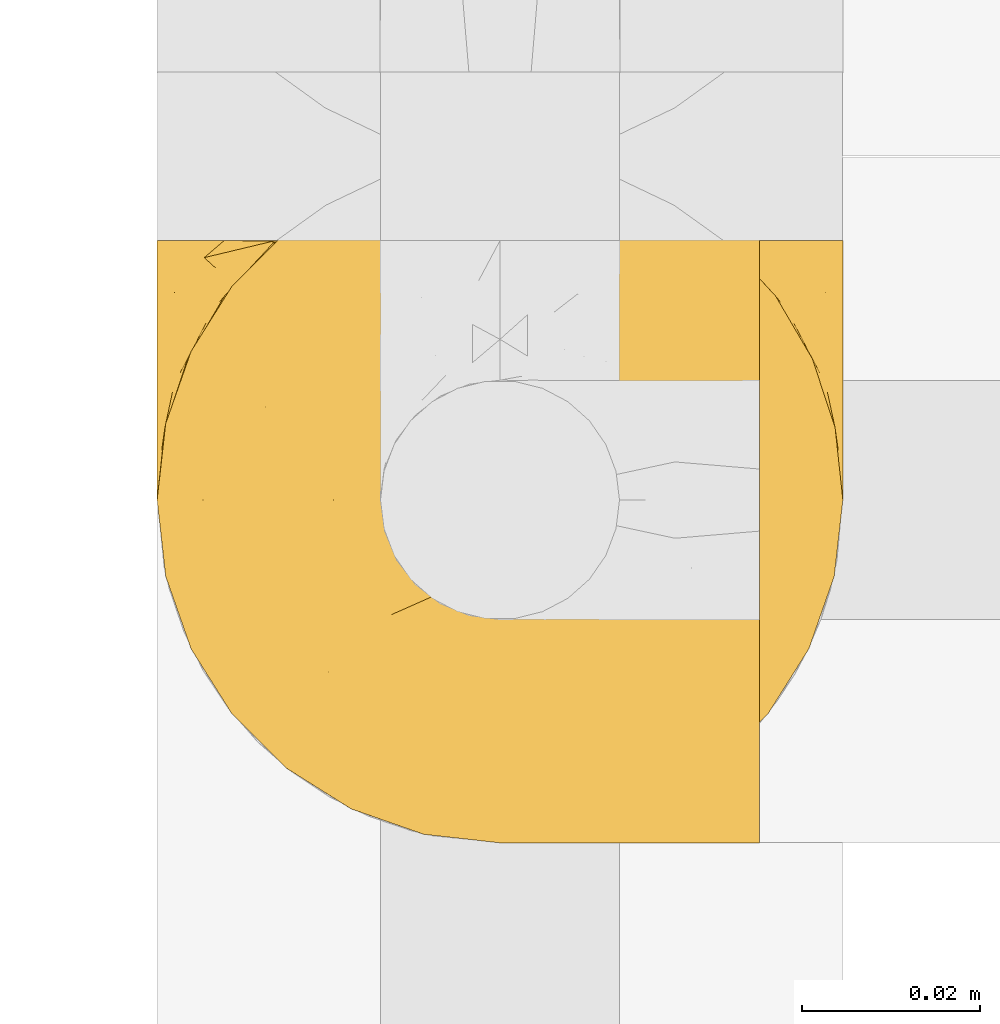
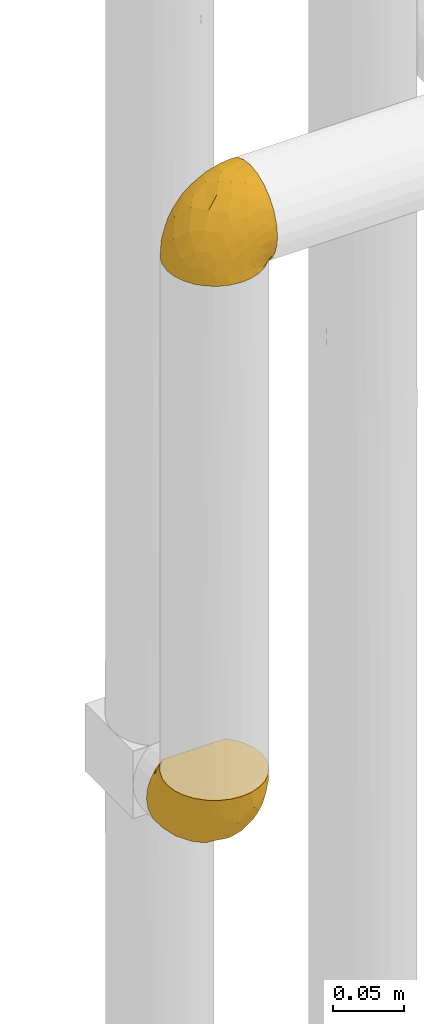
# One storey, part 289 of 827: 2 coverings.
"""IFC2X3 building model written with IfcOpenShell, lengths in millimetres."""

import ifcopenshell
import ifcopenshell.guid

model = None  # the IFC model being written
_history = None  # IfcOwnerHistory: only IFC2X3 demands one
_inside = {}  # id of a spatial element -> (the spatial element, [elements in it])
_under = {}  # id of a project, library or spatial element -> (it, [spatial elements below it])
_declared = {}  # id of a project -> (the project, [libraries it declares])
_typed = {}  # id of a type object -> (the type object, [elements of that type])
_made_of = {}  # id of a material, layer set ... -> (it, [elements and type objects made of it])


def new_model(schema):
    """Start an empty IFC model of exactly this schema.

    Asked for "IFC4X3", IfcOpenShell would pick the latest addendum, in which some entities
    have other attributes; the version numbers below select the first issue.
    IFC2X3 requires an IfcOwnerHistory on every rooted entity: one is made here for all.
    """
    global model, _history
    if schema == "IFC4X3":
        model = ifcopenshell.file(schema_version=(4, 3, 0, 0))
    else:
        model = ifcopenshell.file(schema=schema)
    _inside.clear()
    _under.clear()
    _declared.clear()
    _typed.clear()
    _made_of.clear()
    _history = None
    if model.schema == "IFC2X3":
        org = make("IfcOrganization", Name="unknown")
        user = make(
            "IfcPersonAndOrganization",
            ThePerson=make("IfcPerson", FamilyName="unknown"),
            TheOrganization=org,
        )
        app = make(
            "IfcApplication",
            ApplicationDeveloper=org,
            Version="unknown",
            ApplicationFullName="unknown",
            ApplicationIdentifier="unknown",
        )
        _history = make(
            "IfcOwnerHistory",
            OwningUser=user,
            OwningApplication=app,
            ChangeAction="ADDED",
            CreationDate=0,
        )
    return model


def make(cls, **values):
    """One entity of the class cls with the attributes given. An attribute that is None is left unset."""
    return model.create_entity(
        cls, **{name: value for name, value in values.items() if value is not None}
    )


def entity(cls, *values):
    """Any entity or typed value of the class cls, its attributes in the order of the schema. None: left unset."""
    e = model.create_entity(cls)
    for i, value in enumerate(values):
        if value is not None:
            e[i] = value
    return e


def rooted(cls, **values):
    """An entity with a GlobalId (a new one), such as an element, a storey or a relation."""
    return make(cls, GlobalId=ifcopenshell.guid.new(), OwnerHistory=_history, **values)


def si_unit(unit_type, name, prefix=None):
    """IfcSIUnit, for example si_unit("LENGTHUNIT", "METRE", prefix="MILLI")."""
    return make("IfcSIUnit", UnitType=unit_type, Prefix=prefix, Name=name)


def converted_unit(unit_type, name, factor, base, dimensions=None, offset=None):
    """IfcConversionBasedUnit, such as the inch: factor (a typed value) times the base unit."""
    return make(
        "IfcConversionBasedUnit"
        if offset is None
        else "IfcConversionBasedUnitWithOffset",
        ConversionOffset=offset,
        Dimensions=None
        if dimensions is None
        else entity("IfcDimensionalExponents", *dimensions),
        UnitType=unit_type,
        Name=name,
        ConversionFactor=make(
            "IfcMeasureWithUnit", ValueComponent=factor, UnitComponent=base
        ),
    )


def derived_unit(unit_type, elements):
    """IfcDerivedUnit: a product of units, each with its exponent."""
    return make(
        "IfcDerivedUnit",
        Elements=[
            make("IfcDerivedUnitElement", Unit=unit, Exponent=power)
            for unit, power in elements
        ],
        UnitType=unit_type,
    )


def assignment(units):
    """IfcUnitAssignment: the units of a project."""
    return None if units is None else make("IfcUnitAssignment", Units=units)


def point(xyz):
    """IfcCartesianPoint."""
    return None if xyz is None else make("IfcCartesianPoint", Coordinates=xyz)


def direction(xyz):
    """IfcDirection."""
    return None if xyz is None else make("IfcDirection", DirectionRatios=xyz)


def frame(location, z_axis=None, x_axis=None):
    """IfcAxis2Placement3D, a coordinate frame: its origin and axes. An axis left out is left unset."""
    return make(
        "IfcAxis2Placement3D",
        Location=point(location),
        Axis=direction(z_axis),
        RefDirection=direction(x_axis),
    )


def origin():
    """The frame at (0, 0, 0) with its axes left unset."""
    return frame((0.0, 0.0, 0.0))


def place(relative_to, where):
    """IfcLocalPlacement: puts the frame where relative to a parent placement (None: the world)."""
    return make(
        "IfcLocalPlacement", PlacementRelTo=relative_to, RelativePlacement=where
    )


def context(
    kind, dimensions, precision=None, world=None, true_north=None, identifier=None
):
    """IfcGeometricRepresentationContext, for example the 3D "Model" context."""
    return make(
        "IfcGeometricRepresentationContext",
        ContextIdentifier=identifier,
        ContextType=kind,
        CoordinateSpaceDimension=dimensions,
        Precision=precision,
        WorldCoordinateSystem=world,
        TrueNorth=true_north,
    )


def subcontext(parent, identifier, kind, view, scale=None):
    """IfcGeometricRepresentationSubContext, for example "Body" below "Model"."""
    return make(
        "IfcGeometricRepresentationSubContext",
        ContextIdentifier=identifier,
        ContextType=kind,
        ParentContext=parent,
        TargetScale=scale,
        TargetView=view,
    )


def project(units=None, contexts=None):
    """IfcProject with its units and contexts."""
    return rooted(
        "IfcProject",
        Name="project",
        RepresentationContexts=contexts,
        UnitsInContext=assignment(units),
    )


def spatial(cls, under=None, at=None, **own):
    """A site, building, storey or space (cls), placed at a placement, below another one or the project."""
    s = rooted(cls, ObjectPlacement=at, **own)
    if under is not None:
        _under.setdefault(under.id(), (under, []))[1].append(s)
    return s


def faces_of(points, faces, orient=None, outer=None):
    """IfcFace entities. A face is a list of loops; a loop is a list of indices into points, from 0.

    orient and outer hold one flag for each loop. By default every Orientation is true, the
    first loop of a face is its IfcFaceOuterBound and the others are IfcFaceBound.
    """
    made = []
    for i, loops in enumerate(faces):
        bounds = []
        for j, loop in enumerate(loops):
            is_outer = j == 0 if outer is None else outer[i][j]
            bounds.append(
                make(
                    "IfcFaceOuterBound" if is_outer else "IfcFaceBound",
                    Bound=make("IfcPolyLoop", Polygon=[points[k] for k in loop]),
                    Orientation=True if orient is None else orient[i][j],
                )
            )
        made.append(make("IfcFace", Bounds=bounds))
    return made


def faceted_brep(points, faces, orient=None, outer=None, voids=None):
    """IfcFacetedBrep: a solid bounded by flat faces; with voids (closed shells), ...WithVoids."""
    shared = [point(p) for p in points]
    hull = make("IfcClosedShell", CfsFaces=faces_of(shared, faces, orient, outer))
    if voids is None:
        return make("IfcFacetedBrep", Outer=hull)
    return make(
        "IfcFacetedBrepWithVoids",
        Outer=hull,
        Voids=[
            make(cls, CfsFaces=faces_of(shared, fs, o, b)) for cls, fs, o, b in voids
        ],
    )


def shape(context_of_items, identifier, shape_type, items):
    """IfcShapeRepresentation: the items that make up one representation, for example the "Body"."""
    return make(
        "IfcShapeRepresentation",
        ContextOfItems=context_of_items,
        RepresentationIdentifier=identifier,
        RepresentationType=shape_type,
        Items=items,
    )


def made_of(thing, what):
    """Note that an element or type object is made of a material, layer set ...; save() writes the relation."""
    if what is not None:
        _made_of.setdefault(what.id(), (what, []))[1].append(thing)
    return thing


def element(
    cls,
    number,
    at=None,
    inside=None,
    cuts=None,
    type_object=None,
    material=None,
    context=None,
    identifier="Body",
    shape_type=None,
    held_by="IfcProductDefinitionShape",
    body=None,
    shapes=None,
    **own,
):
    """One element of the class cls, such as IfcWall. Its Tag is "e" and its number.

    at: its placement. inside: the storey or other place that contains it. cuts: it is an
    opening in that element (IfcRelVoidsElement). A single representation is given by context,
    identifier, shape_type and body (its items); several are given by shapes. held_by: the class
    of the entity that holds the representations. save() writes the other relations.
    """
    e = rooted(cls, Tag="e%d" % number, ObjectPlacement=at, **own)
    if body is not None:
        shapes = [shape(context, identifier, shape_type, body)]
    if shapes is not None:
        e.Representation = make(held_by, Representations=shapes)
    if inside is not None:
        _inside.setdefault(inside.id(), (inside, []))[1].append(e)
    if cuts is not None:
        rooted(
            "IfcRelVoidsElement", RelatingBuildingElement=cuts, RelatedOpeningElement=e
        )
    if type_object is not None:
        _typed.setdefault(type_object.id(), (type_object, []))[1].append(e)
    return made_of(e, material)


def aggregate(whole, parts):
    """IfcRelAggregates: a whole, such as a stair, and the parts it consists of."""
    return rooted("IfcRelAggregates", RelatingObject=whole, RelatedObjects=parts)


def save(model, path):
    """Write the relations noted so far, then the file.

    IfcRelAggregates (storeys below a building ...), IfcRelContainedInSpatialStructure (elements
    in a storey), IfcRelDefinesByType, IfcRelAssociatesMaterial and IfcRelDeclares: one each for
    every whole, place, type object, material and project.
    """
    for whole, parts in _under.values():
        aggregate(whole, parts)
    for where, things in _inside.values():
        rooted(
            "IfcRelContainedInSpatialStructure",
            RelatedElements=things,
            RelatingStructure=where,
        )
    for kind, things in _typed.values():
        rooted("IfcRelDefinesByType", RelatedObjects=things, RelatingType=kind)
    for what, things in _made_of.values():
        rooted("IfcRelAssociatesMaterial", RelatedObjects=things, RelatingMaterial=what)
    for by, libraries in _declared.values():
        rooted("IfcRelDeclares", RelatingContext=by, RelatedDefinitions=libraries)
    model.write(path)


model = new_model("IFC2X3")

# Units and contexts
model_context = context("Model", 3, precision=0.01, world=origin(), true_north=direction((6.12303176911189e-17, 1.0)))
body_context = subcontext(model_context, "Body", "Model", "MODEL_VIEW")
ifc_project = project(units=[si_unit("LENGTHUNIT", "METRE", prefix="MILLI"), si_unit("AREAUNIT", "SQUARE_METRE"), si_unit("VOLUMEUNIT", "CUBIC_METRE"), converted_unit("PLANEANGLEUNIT", "DEGREE", entity("IfcRatioMeasure", 0.0174532925199433), si_unit("PLANEANGLEUNIT", "RADIAN"), dimensions=[0, 0, 0, 0, 0, 0, 0]), si_unit("MASSUNIT", "GRAM", prefix="KILO"), derived_unit("MASSDENSITYUNIT", [(si_unit("MASSUNIT", "GRAM", prefix="KILO"), 1), (si_unit("LENGTHUNIT", "METRE"), -3)]), derived_unit("MOMENTOFINERTIAUNIT", [(si_unit("LENGTHUNIT", "METRE"), 4)]), si_unit("TIMEUNIT", "SECOND"), si_unit("FREQUENCYUNIT", "HERTZ"), si_unit("THERMODYNAMICTEMPERATUREUNIT", "DEGREE_CELSIUS"), derived_unit("THERMALTRANSMITTANCEUNIT", [(si_unit("MASSUNIT", "GRAM", prefix="KILO"), 1), (si_unit("THERMODYNAMICTEMPERATUREUNIT", "KELVIN"), -1), (si_unit("TIMEUNIT", "SECOND"), -3)]), derived_unit("VOLUMETRICFLOWRATEUNIT", [(si_unit("LENGTHUNIT", "METRE"), 3), (si_unit("TIMEUNIT", "SECOND"), -1)]), derived_unit("MASSFLOWRATEUNIT", [(si_unit("MASSUNIT", "GRAM", prefix="KILO"), 1), (si_unit("TIMEUNIT", "SECOND"), -1)]), derived_unit("ROTATIONALFREQUENCYUNIT", [(si_unit("TIMEUNIT", "SECOND"), -1)]), si_unit("ELECTRICCURRENTUNIT", "AMPERE"), si_unit("ELECTRICVOLTAGEUNIT", "VOLT"), si_unit("POWERUNIT", "WATT"), si_unit("FORCEUNIT", "NEWTON", prefix="KILO"), si_unit("ILLUMINANCEUNIT", "LUX"), si_unit("LUMINOUSFLUXUNIT", "LUMEN"), si_unit("LUMINOUSINTENSITYUNIT", "CANDELA"), derived_unit("USERDEFINED", [(si_unit("MASSUNIT", "GRAM", prefix="KILO"), -1), (si_unit("LENGTHUNIT", "METRE"), -2), (si_unit("TIMEUNIT", "SECOND"), 3), (si_unit("LUMINOUSFLUXUNIT", "LUMEN"), 1)]), derived_unit("LINEARVELOCITYUNIT", [(si_unit("LENGTHUNIT", "METRE"), 1), (si_unit("TIMEUNIT", "SECOND"), -1)]), si_unit("PRESSUREUNIT", "PASCAL"), derived_unit("USERDEFINED", [(si_unit("LENGTHUNIT", "METRE"), -2), (si_unit("MASSUNIT", "GRAM", prefix="KILO"), 1), (si_unit("TIMEUNIT", "SECOND"), -2)]), derived_unit("LINEARFORCEUNIT", [(si_unit("MASSUNIT", "GRAM", prefix="KILO"), 1), (si_unit("LENGTHUNIT", "METRE"), 1), (si_unit("TIMEUNIT", "SECOND"), -2), (si_unit("LENGTHUNIT", "METRE"), -1)]), derived_unit("PLANARFORCEUNIT", [(si_unit("MASSUNIT", "GRAM", prefix="KILO"), 1), (si_unit("LENGTHUNIT", "METRE"), 1), (si_unit("TIMEUNIT", "SECOND"), -2), (si_unit("LENGTHUNIT", "METRE"), -2)])], contexts=[model_context])

# Site, building, storey
site_placement = place(None, origin())
site = spatial("IfcSite", under=ifc_project, at=site_placement, CompositionType="ELEMENT")
building_placement = place(site_placement, origin())
building = spatial("IfcBuilding", under=site, at=building_placement, CompositionType="ELEMENT")
storey_placement = place(building_placement, frame((0.0, 0.0, 28200.0)))
storey = spatial("IfcBuildingStorey", under=building, at=storey_placement, Name="08", CompositionType="ELEMENT", Elevation=28200.0)

# Coverings
covering_1_placement = place(storey_placement, frame((34787.8, 15705.01, 2179.3)))
element("IfcCovering", 1, at=covering_1_placement, inside=storey, Name=":ADSK_", ObjectType=":ADSK_", PredefinedType="INSULATION", context=body_context, shape_type="Brep", body=[
    faceted_brep([(23.36, 5.41, 1.6), (16.07, 9.99, 1.6), (9.98, 16.08, 1.6), (5.4, 23.37, 1.6), (2.56, 31.49, 1.6), (1.6, 40.05, 1.6), (2.56, 48.61, 1.6), (5.41, 56.73, 1.6), (9.99, 64.02, 1.6), (16.08, 70.11, 1.6), (23.37, 74.69, 1.6), (31.49, 77.53, 1.6), (40.05, 78.5, 1.6), (48.15, 77.63, 1.6), (55.88, 75.08, 1.6), (62.9, 70.97, 1.6), (68.89, 65.47, 1.6), (68.89, 63.27, 1.6), (68.89, 61.53, 1.6), (68.89, 59.57, 1.6), (68.89, 57.6, 1.6), (68.89, 55.63, 1.6), (68.89, 53.67, 1.6), (68.89, 51.7, 1.6), (68.89, 49.73, 1.6), (68.89, 47.54, 1.6), (68.89, 45.34, 1.6), (68.89, 43.15, 1.6), (68.89, 40.96, 1.6), (68.89, 38.76, 1.6), (68.89, 36.57, 1.6), (68.89, 34.37, 1.6), (68.89, 32.18, 1.6), (68.89, 29.98, 1.6), (68.89, 27.79, 1.6), (68.89, 25.6, 1.6), (68.89, 23.4, 1.6), (68.89, 21.21, 1.6), (68.89, 19.01, 1.6), (68.89, 16.82, 1.6), (68.89, 14.62, 1.6), (62.89, 9.12, 1.6), (55.86, 5.0, 1.6), (48.13, 2.46, 1.6), (40.05, 1.6, 1.6), (31.49, 2.56, 1.6), (69.15, 65.47, 1.85), (69.15, 70.97, 7.85), (69.15, 75.09, 14.87), (69.15, 77.63, 22.6), (69.15, 78.5, 30.7), (69.15, 77.19, 40.65), (69.15, 73.34, 49.92), (69.15, 67.23, 57.88), (69.15, 59.27, 63.99), (69.15, 50.0, 67.84), (69.15, 40.05, 69.15), (69.15, 30.09, 67.84), (69.15, 20.82, 63.99), (69.15, 12.86, 57.88), (69.15, 6.75, 49.92), (69.15, 2.91, 40.65), (69.15, 1.6, 30.7), (69.15, 2.46, 22.6), (69.15, 5.0, 14.87), (69.15, 9.12, 7.85), (69.15, 14.62, 1.85), (69.15, 16.82, 1.85), (69.15, 17.8, 1.85), (69.15, 19.39, 1.85), (69.15, 20.98, 1.85), (69.15, 22.57, 1.85), (69.15, 24.16, 1.85), (69.15, 25.75, 1.85), (69.15, 27.33, 1.85), (69.15, 28.92, 1.85), (69.15, 30.51, 1.85), (69.15, 32.1, 1.85), (69.15, 33.69, 1.85), (69.15, 35.28, 1.85), (69.15, 36.87, 1.85), (69.15, 38.46, 1.85), (69.15, 40.05, 1.85), (69.15, 41.63, 1.85), (69.15, 43.22, 1.85), (69.15, 44.81, 1.85), (69.15, 46.4, 1.85), (69.15, 47.99, 1.85), (69.15, 49.58, 1.85), (69.15, 51.17, 1.85), (69.15, 52.76, 1.85), (69.15, 54.72, 1.85), (69.15, 56.69, 1.85), (69.15, 58.88, 1.85), (69.15, 61.08, 1.85), (69.15, 63.27, 1.85), (68.96, 37.77, 1.77), (68.97, 36.07, 1.78), (68.97, 32.96, 1.77), (68.97, 31.36, 1.77), (68.95, 56.52, 1.76), (68.96, 54.96, 1.77), (68.98, 18.75, 1.79), (68.97, 58.07, 1.78), (68.97, 50.37, 1.78), (68.98, 23.36, 1.78), (68.97, 24.95, 1.78), (68.97, 42.43, 1.78), (68.94, 15.97, 1.74), (68.98, 51.96, 1.78), (68.98, 53.47, 1.78), (68.96, 48.63, 1.77), (68.97, 63.93, 1.78), (68.98, 40.93, 1.78), (68.98, 29.72, 1.78), (68.97, 62.4, 1.77), (68.96, 60.92, 1.77), (68.97, 17.31, 1.77), (68.97, 21.74, 1.78), (68.98, 34.56, 1.78), (68.96, 20.18, 1.77), (68.97, 14.62, 1.77), (68.94, 14.62, 1.72), (68.92, 14.62, 1.66), (68.97, 65.47, 1.77), (69.02, 65.47, 1.8), (69.08, 65.47, 1.82), (68.98, 59.5, 1.79), (68.97, 47.1, 1.78), (68.98, 45.61, 1.79), (68.97, 28.18, 1.78), (69.08, 14.62, 1.82), (69.02, 14.62, 1.8), (68.96, 26.61, 1.76), (68.92, 65.47, 1.66), (68.94, 65.47, 1.72), (68.97, 39.32, 1.78), (68.96, 44.12, 1.77), (67.02, 72.26, 9.41), (63.33, 76.57, 17.65), (64.61, 71.77, 7.41), (49.27, 78.5, 21.47), (51.4, 77.9, 15.21), (43.94, 78.5, 16.15), (61.87, 78.5, 28.75), (61.54, 75.52, 13.67), (57.95, 76.13, 12.79), (56.12, 77.81, 19.18), (63.4, 78.5, 29.16), (65.41, 72.4, 9.04), (53.1, 76.56, 7.41), (63.04, 71.77, 5.74), (61.33, 72.25, 3.72), (41.99, 78.5, 8.87), (54.6, 78.5, 26.8), (56.6, 75.75, 9.53), (41.58, 78.5, 7.34), (13.72, 50.46, 37.63), (5.82, 52.75, 17.92), (6.74, 40.05, 27.45), (58.82, 77.7, 37.01), (51.58, 77.66, 34.22), (42.09, 71.02, 45.87), (46.12, 63.45, 56.57), (55.56, 70.55, 52.31), (52.38, 75.57, 42.07), (61.54, 75.57, 44.74), (23.76, 72.61, 21.49), (20.5, 72.61, 11.02), (14.64, 67.24, 15.64), (41.77, 77.74, 26.02), (16.28, 57.43, 36.59), (49.4, 47.19, 65.49), (52.34, 54.76, 63.99), (4.3, 40.05, 15.2), (58.67, 63.45, 60.27), (25.26, 60.1, 45.25), (20.17, 63.72, 35.21), (34.7, 76.83, 22.52), (28.67, 76.34, 12.03), (8.62, 60.51, 13.32), (33.37, 72.59, 35.9), (41.35, 76.05, 33.87), (17.15, 66.15, 25.73), (12.68, 60.51, 26.34), (21.47, 51.88, 46.78), (41.11, 55.34, 59.54), (37.53, 48.67, 60.18), (30.64, 53.89, 53.93), (26.66, 46.73, 53.36), (21.38, 40.05, 49.36), (14.06, 40.05, 38.4), (55.54, 40.05, 66.44), (35.17, 63.95, 50.09), (29.04, 67.24, 41.08), (24.34, 69.62, 31.14), (29.33, 73.6, 28.19), (43.3, 40.05, 64.0), (32.34, 40.05, 56.68), (57.75, 4.52, 43.9), (49.41, 32.72, 65.46), (27.85, 27.18, 52.22), (13.7, 29.63, 37.61), (14.63, 12.86, 15.64), (8.61, 19.59, 13.31), (48.85, 9.54, 50.02), (54.13, 16.64, 59.28), (37.84, 17.48, 53.05), (23.75, 7.49, 21.48), (20.49, 7.49, 11.01), (28.66, 3.75, 12.03), (20.83, 20.75, 41.02), (55.15, 2.33, 35.39), (54.6, 1.6, 26.8), (61.87, 1.6, 28.75), (41.58, 1.6, 7.34), (57.58, 26.94, 65.81), (59.91, 9.54, 53.28), (36.94, 31.21, 59.8), (45.72, 25.33, 61.82), (5.82, 27.35, 17.91), (37.91, 8.17, 41.4), (50.18, 4.3, 40.48), (12.67, 19.59, 26.34), (49.29, 2.23, 31.68), (42.64, 2.45, 27.68), (43.94, 1.6, 16.15), (49.27, 1.6, 21.47), (19.45, 12.86, 28.05), (34.7, 3.27, 22.54), (41.99, 1.6, 8.87), (62.29, 2.29, 37.3), (29.01, 12.86, 41.07), (31.47, 6.89, 32.24), (37.18, 12.43, 47.4), (43.45, 4.1, 35.77), (63.33, 3.53, 17.65), (67.23, 6.88, 11.06), (66.07, 8.16, 8.55), (65.22, 9.02, 6.63), (61.99, 5.0, 12.77), (57.95, 3.96, 12.79), (53.09, 3.52, 7.41), (56.84, 2.4, 18.97), (61.33, 7.83, 3.72), (63.06, 8.32, 5.76), (51.41, 2.19, 15.21), (56.61, 4.34, 9.52)], [[[0, 1, 2, 3, 4, 5, 6, 7, 8, 9, 10, 11, 12, 13, 14, 15, 16, 17, 18, 19, 20, 21, 22, 23, 24, 25, 26, 27, 28, 29, 30, 31, 32, 33, 34, 35, 36, 37, 38, 39, 40, 41, 42, 43, 44, 45]], [[46, 47, 48, 49, 50, 51, 52, 53, 54, 55, 56, 57, 58, 59, 60, 61, 62, 63, 64, 65, 66, 67, 68, 69, 70, 71, 72, 73, 74, 75, 76, 77, 78, 79, 80, 81, 82, 83, 84, 85, 86, 87, 88, 89, 90, 91, 92, 93, 94, 95]], [[96, 97, 30]], [[98, 77, 99]], [[100, 101, 21]], [[69, 68, 102]], [[20, 19, 103]], [[24, 23, 104]], [[20, 103, 100]], [[72, 105, 106]], [[84, 83, 107]], [[89, 88, 104]], [[108, 67, 66]], [[109, 110, 90]], [[111, 25, 24]], [[112, 17, 16]], [[82, 113, 83]], [[109, 23, 22]], [[114, 76, 75]], [[105, 36, 106]], [[104, 111, 24]], [[18, 115, 116]], [[97, 96, 80]], [[67, 108, 117]], [[105, 71, 118]], [[31, 97, 119]], [[102, 120, 69]], [[108, 121, 122, 123, 40]], [[112, 95, 115]], [[17, 115, 18]], [[94, 116, 115]], [[117, 68, 67]], [[38, 117, 39]], [[112, 124, 125, 126, 46]], [[17, 112, 115]], [[70, 120, 118]], [[39, 117, 108]], [[120, 38, 37]], [[120, 37, 118]], [[120, 70, 69]], [[116, 94, 127]], [[128, 86, 129]], [[117, 38, 102]], [[74, 130, 75]], [[99, 33, 32]], [[115, 95, 94]], [[39, 108, 40]], [[108, 66, 131, 132, 121]], [[105, 72, 71]], [[118, 37, 36]], [[71, 70, 118]], [[35, 106, 36]], [[36, 105, 118]], [[35, 133, 106]], [[74, 73, 133]], [[106, 133, 73]], [[99, 114, 33]], [[133, 35, 34]], [[73, 72, 106]], [[95, 112, 46]], [[112, 16, 134, 135, 124]], [[130, 114, 75]], [[99, 76, 114]], [[114, 130, 33]], [[34, 33, 130]], [[78, 77, 98]], [[98, 119, 78]], [[130, 133, 34]], [[133, 130, 74]], [[79, 97, 80]], [[98, 99, 32]], [[98, 32, 31]], [[77, 76, 99]], [[97, 79, 119]], [[136, 96, 29]], [[30, 97, 31]], [[136, 29, 28]], [[81, 80, 96]], [[29, 96, 30]], [[31, 119, 98]], [[119, 79, 78]], [[96, 136, 81]], [[82, 81, 136]], [[113, 107, 83]], [[84, 107, 137]], [[107, 27, 137]], [[113, 28, 107]], [[27, 107, 28]], [[85, 84, 137]], [[137, 27, 26]], [[113, 136, 28]], [[136, 113, 82]], [[109, 89, 104]], [[86, 85, 129]], [[89, 109, 90]], [[111, 87, 128]], [[26, 129, 137]], [[88, 111, 104]], [[25, 111, 128]], [[22, 110, 109]], [[23, 109, 104]], [[110, 91, 90]], [[100, 92, 101]], [[110, 22, 101]], [[91, 110, 101]], [[116, 19, 18]], [[111, 88, 87]], [[127, 103, 19]], [[25, 128, 26]], [[86, 128, 87]], [[128, 129, 26]], [[137, 129, 85]], [[120, 102, 38]], [[117, 102, 68]], [[91, 101, 92]], [[21, 101, 22]], [[93, 92, 103]], [[100, 21, 20]], [[100, 103, 92]], [[127, 93, 103]], [[93, 127, 94]], [[116, 127, 19]], [[126, 138, 47]], [[48, 138, 139]], [[140, 125, 124]], [[141, 142, 143]], [[144, 49, 139]], [[145, 140, 146]], [[48, 139, 49]], [[139, 145, 147]], [[49, 144, 148, 50]], [[126, 125, 149]], [[14, 13, 150]], [[151, 146, 140]], [[149, 140, 145]], [[152, 151, 135]], [[152, 14, 150]], [[16, 15, 134]], [[13, 153, 150]], [[124, 151, 140]], [[141, 147, 142]], [[14, 152, 15]], [[15, 152, 134]], [[47, 46, 126]], [[139, 154, 144]], [[138, 48, 47]], [[125, 140, 149]], [[135, 134, 152]], [[146, 155, 142]], [[145, 146, 147]], [[149, 139, 138]], [[147, 141, 154]], [[147, 146, 142]], [[139, 147, 154]], [[139, 149, 145]], [[149, 138, 126]], [[155, 146, 151]], [[150, 143, 142]], [[152, 155, 151]], [[150, 142, 155]], [[13, 12, 156, 153]], [[153, 143, 150]], [[152, 150, 155]], [[151, 124, 135]], [[157, 158, 159]], [[160, 154, 161]], [[162, 163, 164]], [[165, 166, 160]], [[167, 168, 169]], [[141, 170, 161]], [[156, 12, 11]], [[158, 157, 171]], [[172, 55, 173]], [[158, 6, 174]], [[175, 54, 53]], [[52, 166, 164]], [[52, 164, 53]], [[54, 175, 173]], [[166, 52, 51]], [[176, 177, 171]], [[178, 143, 179]], [[156, 11, 179]], [[8, 7, 180]], [[169, 9, 8]], [[179, 143, 153, 156]], [[179, 11, 10]], [[168, 179, 10]], [[181, 162, 182]], [[179, 167, 178]], [[183, 184, 177]], [[183, 169, 184]], [[176, 171, 185]], [[172, 186, 187]], [[158, 7, 6]], [[159, 158, 174]], [[184, 180, 158]], [[54, 173, 55]], [[180, 169, 8]], [[188, 189, 187]], [[9, 168, 10]], [[186, 188, 187]], [[190, 157, 159, 191]], [[55, 172, 192]], [[176, 193, 194]], [[161, 170, 182]], [[162, 164, 165]], [[175, 164, 163]], [[51, 50, 148]], [[167, 195, 196]], [[178, 182, 170]], [[6, 5, 174]], [[158, 180, 7]], [[169, 180, 184]], [[169, 168, 9]], [[179, 168, 167]], [[182, 162, 165]], [[162, 194, 193]], [[161, 165, 160]], [[195, 181, 196]], [[192, 172, 197]], [[192, 56, 55]], [[189, 190, 198]], [[198, 197, 187]], [[172, 187, 197]], [[185, 189, 188]], [[198, 187, 189]], [[186, 172, 173]], [[173, 163, 186]], [[193, 186, 163]], [[176, 185, 188]], [[185, 157, 190]], [[188, 186, 193]], [[177, 176, 194]], [[188, 193, 176]], [[162, 193, 163]], [[195, 177, 194]], [[171, 177, 184]], [[181, 195, 194]], [[183, 167, 169]], [[162, 181, 194]], [[196, 182, 178]], [[158, 171, 184]], [[171, 157, 185]], [[177, 195, 183]], [[167, 183, 195]], [[182, 196, 181]], [[178, 170, 143]], [[178, 167, 196]], [[164, 175, 53]], [[173, 175, 163]], [[160, 51, 148]], [[164, 166, 165]], [[51, 160, 166]], [[160, 148, 144, 154]], [[141, 161, 154]], [[182, 165, 161]], [[190, 189, 185]], [[143, 170, 141]], [[60, 199, 61]], [[197, 200, 192]], [[201, 190, 202]], [[200, 57, 192]], [[203, 204, 2]], [[205, 206, 207]], [[208, 209, 210]], [[211, 207, 201]], [[212, 213, 214]], [[45, 215, 210]], [[216, 206, 58]], [[45, 44, 215]], [[59, 217, 60]], [[60, 217, 199]], [[0, 45, 210]], [[218, 201, 219]], [[202, 159, 220]], [[205, 221, 222]], [[223, 204, 203]], [[1, 203, 2]], [[57, 200, 216]], [[220, 3, 204]], [[220, 174, 4]], [[1, 0, 209]], [[212, 224, 213]], [[225, 226, 227]], [[228, 223, 203]], [[208, 210, 229]], [[210, 226, 229]], [[3, 220, 4]], [[58, 206, 59]], [[209, 203, 1]], [[202, 220, 223]], [[228, 203, 208]], [[202, 211, 201]], [[3, 2, 204]], [[202, 190, 191, 159]], [[210, 215, 230, 226]], [[199, 212, 231]], [[232, 233, 221]], [[233, 208, 229]], [[207, 206, 219]], [[217, 206, 205]], [[227, 224, 225]], [[233, 232, 228]], [[201, 207, 219]], [[234, 232, 221]], [[218, 219, 200]], [[202, 223, 211]], [[174, 220, 159]], [[174, 5, 4]], [[61, 231, 62]], [[220, 204, 223]], [[210, 209, 0]], [[203, 209, 208]], [[225, 233, 229]], [[224, 227, 213]], [[221, 233, 235]], [[57, 56, 192]], [[198, 218, 197]], [[200, 219, 216]], [[201, 198, 190]], [[197, 218, 200]], [[198, 201, 218]], [[206, 216, 219]], [[58, 57, 216]], [[231, 212, 214]], [[222, 212, 199]], [[228, 211, 223]], [[207, 211, 232]], [[62, 231, 214]], [[199, 231, 61]], [[233, 228, 208]], [[211, 228, 232]], [[222, 221, 235]], [[234, 205, 207]], [[206, 217, 59]], [[199, 217, 205]], [[205, 222, 199]], [[224, 222, 235]], [[222, 224, 212]], [[224, 235, 225]], [[233, 225, 235]], [[226, 225, 229]], [[205, 234, 221]], [[207, 232, 234]], [[63, 214, 236]], [[214, 213, 236]], [[214, 63, 62]], [[237, 236, 238]], [[238, 132, 131]], [[236, 237, 64]], [[239, 240, 241]], [[63, 236, 64]], [[131, 66, 65]], [[237, 131, 65]], [[242, 230, 43]], [[237, 65, 64]], [[239, 121, 132]], [[42, 242, 43]], [[241, 240, 243]], [[41, 123, 244]], [[43, 230, 215, 44]], [[244, 122, 245]], [[227, 246, 243]], [[241, 247, 245]], [[121, 239, 245]], [[41, 40, 123]], [[132, 238, 239]], [[244, 42, 41]], [[131, 237, 238]], [[240, 239, 238]], [[245, 239, 241]], [[247, 241, 246]], [[247, 244, 245]], [[238, 236, 240]], [[243, 236, 213]], [[236, 243, 240]], [[227, 226, 246]], [[243, 213, 227]], [[242, 246, 226]], [[243, 246, 241]], [[246, 242, 247]], [[244, 247, 242]], [[242, 226, 230]], [[42, 244, 242]], [[122, 244, 123]], [[122, 121, 245]]]),
])
covering_2_placement = place(storey_placement, frame((34787.8, 15705.01, 1669.95)))
element("IfcCovering", 2, at=covering_2_placement, inside=storey, Name=":ADSK_", ObjectType=":ADSK_", PredefinedType="INSULATION", context=body_context, shape_type="Brep", body=[
    faceted_brep([(5.41, 23.36, 69.15), (9.99, 16.07, 69.15), (16.08, 9.98, 69.15), (23.37, 5.4, 69.15), (31.49, 2.56, 69.15), (40.05, 1.6, 69.15), (48.61, 2.56, 69.15), (56.73, 5.41, 69.15), (64.02, 9.99, 69.15), (70.11, 16.08, 69.15), (74.69, 23.37, 69.15), (77.53, 31.49, 69.15), (78.5, 40.05, 69.15), (77.63, 48.15, 69.15), (75.08, 55.88, 69.15), (70.97, 62.9, 69.15), (65.47, 68.89, 69.15), (63.27, 68.89, 69.15), (61.53, 68.89, 69.15), (59.57, 68.89, 69.15), (57.6, 68.89, 69.15), (55.63, 68.89, 69.15), (53.67, 68.89, 69.15), (51.7, 68.89, 69.15), (49.73, 68.89, 69.15), (47.54, 68.89, 69.15), (45.34, 68.89, 69.15), (43.15, 68.89, 69.15), (40.96, 68.89, 69.15), (38.76, 68.89, 69.15), (36.57, 68.89, 69.15), (34.37, 68.89, 69.15), (32.18, 68.89, 69.15), (29.98, 68.89, 69.15), (27.79, 68.89, 69.15), (25.6, 68.89, 69.15), (23.4, 68.89, 69.15), (21.21, 68.89, 69.15), (19.01, 68.89, 69.15), (16.82, 68.89, 69.15), (14.62, 68.89, 69.15), (9.12, 62.89, 69.15), (5.0, 55.86, 69.15), (2.46, 48.13, 69.15), (1.6, 40.05, 69.15), (2.56, 31.49, 69.15), (65.47, 69.15, 68.89), (70.97, 69.15, 62.89), (75.09, 69.15, 55.87), (77.63, 69.15, 48.14), (78.5, 69.15, 40.05), (77.19, 69.15, 30.09), (73.34, 69.15, 20.82), (67.23, 69.15, 12.86), (59.27, 69.15, 6.75), (50.0, 69.15, 2.91), (40.05, 69.15, 1.6), (30.09, 69.15, 2.91), (20.82, 69.15, 6.75), (12.86, 69.15, 12.86), (6.75, 69.15, 20.82), (2.91, 69.15, 30.09), (1.6, 69.15, 40.05), (2.46, 69.15, 48.14), (5.0, 69.15, 55.87), (9.12, 69.15, 62.89), (14.62, 69.15, 68.89), (16.82, 69.15, 68.89), (17.8, 69.15, 68.89), (19.39, 69.15, 68.89), (20.98, 69.15, 68.89), (22.57, 69.15, 68.89), (24.16, 69.15, 68.89), (25.75, 69.15, 68.89), (27.33, 69.15, 68.89), (28.92, 69.15, 68.89), (30.51, 69.15, 68.89), (32.1, 69.15, 68.89), (33.69, 69.15, 68.89), (35.28, 69.15, 68.89), (36.87, 69.15, 68.89), (38.46, 69.15, 68.89), (40.05, 69.15, 68.89), (41.63, 69.15, 68.89), (43.22, 69.15, 68.89), (44.81, 69.15, 68.89), (46.4, 69.15, 68.89), (47.99, 69.15, 68.89), (49.58, 69.15, 68.89), (51.17, 69.15, 68.89), (52.76, 69.15, 68.89), (54.72, 69.15, 68.89), (56.69, 69.15, 68.89), (58.88, 69.15, 68.89), (61.08, 69.15, 68.89), (63.27, 69.15, 68.89), (37.77, 68.96, 68.97), (36.07, 68.97, 68.96), (32.96, 68.97, 68.97), (31.36, 68.97, 68.97), (56.52, 68.95, 68.98), (54.96, 68.96, 68.97), (18.75, 68.98, 68.96), (58.07, 68.97, 68.96), (50.37, 68.97, 68.96), (23.36, 68.98, 68.96), (24.95, 68.97, 68.96), (42.43, 68.97, 68.96), (15.97, 68.94, 69.0), (51.96, 68.98, 68.96), (53.47, 68.98, 68.96), (48.63, 68.96, 68.97), (63.93, 68.97, 68.96), (40.93, 68.98, 68.96), (29.72, 68.98, 68.96), (62.4, 68.97, 68.97), (60.92, 68.96, 68.97), (17.31, 68.97, 68.97), (21.74, 68.97, 68.96), (34.56, 68.98, 68.96), (20.18, 68.96, 68.97), (14.62, 68.97, 68.97), (14.62, 68.94, 69.02), (14.62, 68.92, 69.08), (65.47, 68.97, 68.97), (65.47, 69.02, 68.94), (65.47, 69.08, 68.92), (59.5, 68.98, 68.96), (47.1, 68.97, 68.96), (45.61, 68.98, 68.95), (28.18, 68.97, 68.96), (14.62, 69.08, 68.92), (14.62, 69.02, 68.94), (26.61, 68.96, 68.98), (65.47, 68.92, 69.08), (65.47, 68.94, 69.02), (39.32, 68.97, 68.96), (44.12, 68.96, 68.97), (72.26, 67.02, 61.33), (76.57, 63.33, 53.1), (71.77, 64.61, 63.33), (78.5, 49.27, 49.27), (77.9, 51.4, 55.53), (78.5, 43.94, 54.6), (78.5, 61.87, 41.99), (75.52, 61.54, 57.07), (76.13, 57.95, 57.95), (77.81, 56.12, 51.56), (78.5, 63.4, 41.58), (72.4, 65.41, 61.7), (76.56, 53.1, 63.33), (71.77, 63.04, 65.0), (72.25, 61.33, 67.02), (78.5, 41.99, 61.87), (78.5, 54.6, 43.94), (75.75, 56.6, 61.21), (78.5, 41.58, 63.4), (50.46, 13.72, 33.11), (52.75, 5.82, 52.82), (40.05, 6.74, 43.3), (77.7, 58.82, 33.73), (77.66, 51.58, 36.52), (71.02, 42.09, 24.87), (63.45, 46.12, 14.17), (70.55, 55.56, 18.43), (75.57, 52.38, 28.67), (75.57, 61.54, 26.0), (72.61, 23.76, 49.25), (72.61, 20.5, 59.72), (67.24, 14.64, 55.1), (77.74, 41.77, 44.72), (57.43, 16.28, 34.15), (47.19, 49.4, 5.25), (54.76, 52.34, 6.75), (40.05, 4.3, 55.54), (63.45, 58.67, 10.47), (60.1, 25.26, 25.49), (63.72, 20.17, 35.53), (76.83, 34.7, 48.22), (76.34, 28.67, 58.71), (60.51, 8.62, 57.42), (72.59, 33.37, 34.84), (76.05, 41.35, 36.87), (66.15, 17.15, 45.01), (60.51, 12.68, 44.4), (51.88, 21.47, 23.96), (55.34, 41.11, 11.2), (48.67, 37.53, 10.56), (53.89, 30.64, 16.81), (46.73, 26.66, 17.38), (40.05, 21.38, 21.38), (40.05, 14.06, 32.34), (40.05, 55.54, 4.3), (63.95, 35.17, 20.65), (67.24, 29.04, 29.66), (69.62, 24.34, 39.6), (73.6, 29.33, 42.55), (40.05, 43.3, 6.74), (40.05, 32.34, 14.06), (4.52, 57.75, 26.84), (32.72, 49.41, 5.28), (27.18, 27.85, 18.52), (29.63, 13.7, 33.13), (12.86, 14.63, 55.1), (19.59, 8.61, 57.43), (9.54, 48.85, 20.72), (16.64, 54.13, 11.46), (17.48, 37.84, 17.69), (7.49, 23.75, 49.26), (7.49, 20.49, 59.73), (3.75, 28.66, 58.71), (20.75, 20.83, 29.72), (2.33, 55.15, 35.35), (1.6, 54.6, 43.94), (1.6, 61.87, 41.99), (1.6, 41.58, 63.4), (26.94, 57.58, 4.93), (9.54, 59.91, 17.46), (31.21, 36.94, 10.94), (25.33, 45.72, 8.92), (27.35, 5.82, 52.83), (8.17, 37.91, 29.34), (4.3, 50.18, 30.26), (19.59, 12.67, 44.4), (2.23, 49.29, 39.06), (2.45, 42.64, 43.06), (1.6, 43.94, 54.6), (1.6, 49.27, 49.27), (12.86, 19.45, 42.69), (3.27, 34.7, 48.2), (1.6, 41.99, 61.87), (2.29, 62.29, 33.44), (12.86, 29.01, 29.67), (6.89, 31.47, 38.5), (12.43, 37.18, 23.35), (4.1, 43.45, 34.97), (3.53, 63.33, 53.1), (6.88, 67.23, 59.68), (8.16, 66.07, 62.19), (9.02, 65.22, 64.11), (5.0, 61.99, 57.97), (3.96, 57.95, 57.95), (3.52, 53.09, 63.33), (2.4, 56.84, 51.77), (7.83, 61.33, 67.02), (8.32, 63.06, 64.98), (2.19, 51.41, 55.53), (4.34, 56.61, 61.22)], [[[0, 1, 2, 3, 4, 5, 6, 7, 8, 9, 10, 11, 12, 13, 14, 15, 16, 17, 18, 19, 20, 21, 22, 23, 24, 25, 26, 27, 28, 29, 30, 31, 32, 33, 34, 35, 36, 37, 38, 39, 40, 41, 42, 43, 44, 45]], [[46, 47, 48, 49, 50, 51, 52, 53, 54, 55, 56, 57, 58, 59, 60, 61, 62, 63, 64, 65, 66, 67, 68, 69, 70, 71, 72, 73, 74, 75, 76, 77, 78, 79, 80, 81, 82, 83, 84, 85, 86, 87, 88, 89, 90, 91, 92, 93, 94, 95]], [[96, 97, 30]], [[98, 77, 99]], [[100, 101, 21]], [[69, 68, 102]], [[20, 19, 103]], [[24, 23, 104]], [[20, 103, 100]], [[72, 105, 106]], [[84, 83, 107]], [[89, 88, 104]], [[108, 67, 66]], [[109, 110, 90]], [[111, 25, 24]], [[112, 17, 16]], [[82, 113, 83]], [[109, 23, 22]], [[114, 76, 75]], [[105, 36, 106]], [[104, 111, 24]], [[18, 115, 116]], [[97, 96, 80]], [[67, 108, 117]], [[105, 71, 118]], [[31, 97, 119]], [[102, 120, 69]], [[108, 121, 122, 123, 40]], [[112, 95, 115]], [[17, 115, 18]], [[94, 116, 115]], [[117, 68, 67]], [[38, 117, 39]], [[112, 124, 125, 126, 46]], [[17, 112, 115]], [[70, 120, 118]], [[39, 117, 108]], [[120, 38, 37]], [[120, 37, 118]], [[120, 70, 69]], [[116, 94, 127]], [[128, 86, 129]], [[117, 38, 102]], [[74, 130, 75]], [[99, 33, 32]], [[115, 95, 94]], [[39, 108, 40]], [[108, 66, 131, 132, 121]], [[105, 72, 71]], [[118, 37, 36]], [[71, 70, 118]], [[35, 106, 36]], [[36, 105, 118]], [[35, 133, 106]], [[74, 73, 133]], [[106, 133, 73]], [[99, 114, 33]], [[133, 35, 34]], [[73, 72, 106]], [[95, 112, 46]], [[112, 16, 134, 135, 124]], [[130, 114, 75]], [[99, 76, 114]], [[114, 130, 33]], [[34, 33, 130]], [[78, 77, 98]], [[98, 119, 78]], [[130, 133, 34]], [[133, 130, 74]], [[79, 97, 80]], [[98, 99, 32]], [[98, 32, 31]], [[77, 76, 99]], [[97, 79, 119]], [[136, 96, 29]], [[30, 97, 31]], [[136, 29, 28]], [[81, 80, 96]], [[29, 96, 30]], [[31, 119, 98]], [[119, 79, 78]], [[96, 136, 81]], [[82, 81, 136]], [[113, 107, 83]], [[84, 107, 137]], [[107, 27, 137]], [[113, 28, 107]], [[27, 107, 28]], [[85, 84, 137]], [[137, 27, 26]], [[113, 136, 28]], [[136, 113, 82]], [[109, 89, 104]], [[86, 85, 129]], [[89, 109, 90]], [[111, 87, 128]], [[26, 129, 137]], [[88, 111, 104]], [[25, 111, 128]], [[22, 110, 109]], [[23, 109, 104]], [[110, 91, 90]], [[100, 92, 101]], [[110, 22, 101]], [[91, 110, 101]], [[116, 19, 18]], [[111, 88, 87]], [[127, 103, 19]], [[25, 128, 26]], [[86, 128, 87]], [[128, 129, 26]], [[137, 129, 85]], [[120, 102, 38]], [[117, 102, 68]], [[91, 101, 92]], [[21, 101, 22]], [[93, 92, 103]], [[100, 21, 20]], [[100, 103, 92]], [[127, 93, 103]], [[93, 127, 94]], [[116, 127, 19]], [[126, 138, 47]], [[48, 138, 139]], [[140, 125, 124]], [[141, 142, 143]], [[144, 49, 139]], [[145, 140, 146]], [[48, 139, 49]], [[139, 145, 147]], [[49, 144, 148, 50]], [[126, 125, 149]], [[14, 13, 150]], [[151, 146, 140]], [[149, 140, 145]], [[152, 151, 135]], [[152, 14, 150]], [[16, 15, 134]], [[13, 153, 150]], [[124, 151, 140]], [[141, 147, 142]], [[14, 152, 15]], [[15, 152, 134]], [[47, 46, 126]], [[139, 154, 144]], [[138, 48, 47]], [[125, 140, 149]], [[135, 134, 152]], [[146, 155, 142]], [[145, 146, 147]], [[149, 139, 138]], [[147, 141, 154]], [[147, 146, 142]], [[139, 147, 154]], [[139, 149, 145]], [[149, 138, 126]], [[155, 146, 151]], [[150, 143, 142]], [[152, 155, 151]], [[150, 142, 155]], [[13, 12, 156, 153]], [[153, 143, 150]], [[152, 150, 155]], [[151, 124, 135]], [[157, 158, 159]], [[160, 154, 161]], [[162, 163, 164]], [[165, 166, 160]], [[167, 168, 169]], [[141, 170, 161]], [[156, 12, 11]], [[158, 157, 171]], [[172, 55, 173]], [[158, 6, 174]], [[175, 54, 53]], [[52, 166, 164]], [[52, 164, 53]], [[54, 175, 173]], [[166, 52, 51]], [[176, 177, 171]], [[178, 143, 179]], [[156, 11, 179]], [[8, 7, 180]], [[169, 9, 8]], [[179, 143, 153, 156]], [[179, 11, 10]], [[168, 179, 10]], [[181, 162, 182]], [[179, 167, 178]], [[183, 184, 177]], [[183, 169, 184]], [[176, 171, 185]], [[172, 186, 187]], [[158, 7, 6]], [[159, 158, 174]], [[184, 180, 158]], [[54, 173, 55]], [[180, 169, 8]], [[188, 189, 187]], [[9, 168, 10]], [[186, 188, 187]], [[190, 157, 159, 191]], [[55, 172, 192]], [[176, 193, 194]], [[161, 170, 182]], [[162, 164, 165]], [[175, 164, 163]], [[51, 50, 148]], [[167, 195, 196]], [[178, 182, 170]], [[6, 5, 174]], [[158, 180, 7]], [[169, 180, 184]], [[169, 168, 9]], [[179, 168, 167]], [[182, 162, 165]], [[162, 194, 193]], [[161, 165, 160]], [[195, 181, 196]], [[192, 172, 197]], [[192, 56, 55]], [[189, 190, 198]], [[198, 197, 187]], [[172, 187, 197]], [[185, 189, 188]], [[198, 187, 189]], [[186, 172, 173]], [[173, 163, 186]], [[193, 186, 163]], [[176, 185, 188]], [[185, 157, 190]], [[188, 186, 193]], [[177, 176, 194]], [[188, 193, 176]], [[162, 193, 163]], [[195, 177, 194]], [[171, 177, 184]], [[181, 195, 194]], [[183, 167, 169]], [[162, 181, 194]], [[196, 182, 178]], [[158, 171, 184]], [[171, 157, 185]], [[177, 195, 183]], [[167, 183, 195]], [[182, 196, 181]], [[178, 170, 143]], [[178, 167, 196]], [[164, 175, 53]], [[173, 175, 163]], [[160, 51, 148]], [[164, 166, 165]], [[51, 160, 166]], [[160, 148, 144, 154]], [[141, 161, 154]], [[182, 165, 161]], [[190, 189, 185]], [[143, 170, 141]], [[60, 199, 61]], [[197, 200, 192]], [[201, 190, 202]], [[200, 57, 192]], [[203, 204, 2]], [[205, 206, 207]], [[208, 209, 210]], [[211, 207, 201]], [[212, 213, 214]], [[45, 215, 210]], [[216, 206, 58]], [[45, 44, 215]], [[59, 217, 60]], [[60, 217, 199]], [[0, 45, 210]], [[218, 201, 219]], [[202, 159, 220]], [[205, 221, 222]], [[223, 204, 203]], [[1, 203, 2]], [[57, 200, 216]], [[220, 3, 204]], [[220, 174, 4]], [[1, 0, 209]], [[212, 224, 213]], [[225, 226, 227]], [[228, 223, 203]], [[208, 210, 229]], [[210, 226, 229]], [[3, 220, 4]], [[58, 206, 59]], [[209, 203, 1]], [[202, 220, 223]], [[228, 203, 208]], [[202, 211, 201]], [[3, 2, 204]], [[202, 190, 191, 159]], [[210, 215, 230, 226]], [[199, 212, 231]], [[232, 233, 221]], [[233, 208, 229]], [[207, 206, 219]], [[217, 206, 205]], [[227, 224, 225]], [[233, 232, 228]], [[201, 207, 219]], [[234, 232, 221]], [[218, 219, 200]], [[202, 223, 211]], [[174, 220, 159]], [[174, 5, 4]], [[61, 231, 62]], [[220, 204, 223]], [[210, 209, 0]], [[203, 209, 208]], [[225, 233, 229]], [[224, 227, 213]], [[221, 233, 235]], [[57, 56, 192]], [[198, 218, 197]], [[200, 219, 216]], [[201, 198, 190]], [[197, 218, 200]], [[198, 201, 218]], [[206, 216, 219]], [[58, 57, 216]], [[231, 212, 214]], [[222, 212, 199]], [[228, 211, 223]], [[207, 211, 232]], [[62, 231, 214]], [[199, 231, 61]], [[233, 228, 208]], [[211, 228, 232]], [[222, 221, 235]], [[234, 205, 207]], [[206, 217, 59]], [[199, 217, 205]], [[205, 222, 199]], [[224, 222, 235]], [[222, 224, 212]], [[224, 235, 225]], [[233, 225, 235]], [[226, 225, 229]], [[205, 234, 221]], [[207, 232, 234]], [[63, 214, 236]], [[214, 213, 236]], [[214, 63, 62]], [[237, 236, 238]], [[238, 132, 131]], [[236, 237, 64]], [[239, 240, 241]], [[63, 236, 64]], [[131, 66, 65]], [[237, 131, 65]], [[242, 230, 43]], [[237, 65, 64]], [[239, 121, 132]], [[42, 242, 43]], [[241, 240, 243]], [[41, 123, 244]], [[43, 230, 215, 44]], [[244, 122, 245]], [[227, 246, 243]], [[241, 247, 245]], [[121, 239, 245]], [[41, 40, 123]], [[132, 238, 239]], [[244, 42, 41]], [[131, 237, 238]], [[240, 239, 238]], [[245, 239, 241]], [[247, 241, 246]], [[247, 244, 245]], [[238, 236, 240]], [[243, 236, 213]], [[236, 243, 240]], [[227, 226, 246]], [[243, 213, 227]], [[242, 246, 226]], [[243, 246, 241]], [[246, 242, 247]], [[244, 247, 242]], [[242, 226, 230]], [[42, 244, 242]], [[122, 244, 123]], [[122, 121, 245]]]),
])

save(model, "model.ifc")
